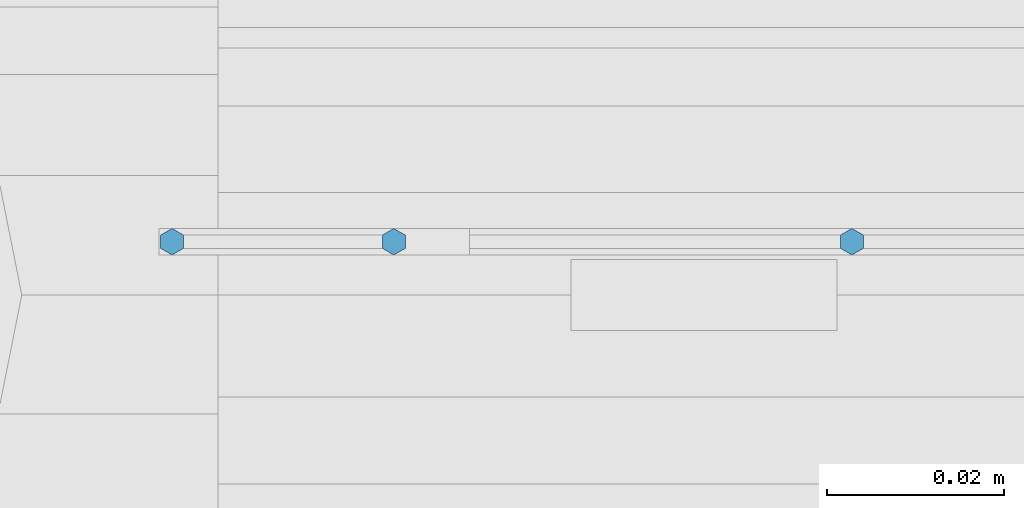
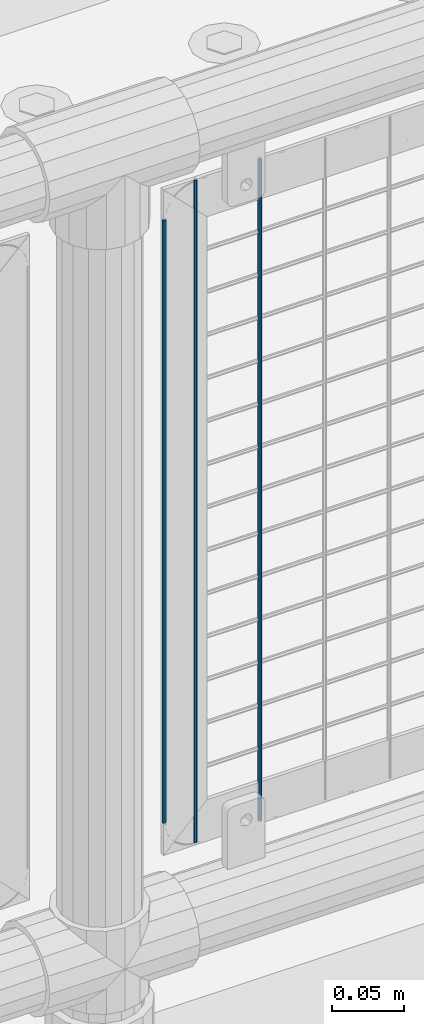
# One storey, part 62 of 193: 3 columns.
"""IFC2X3 building model written with IfcOpenShell, lengths in millimetres."""

from ifc_helpers import new_model, si_unit, frame, origin_with_axes, place, context, subcontext, project, spatial, faceted_brep, material, type_object, element, save


model = new_model("IFC2X3")

# Units and contexts
model_context = context("Model", 3, precision=1e-05, world=origin_with_axes())
body_context = subcontext(model_context, "Body", "Model", "MODEL_VIEW")
ifc_project = project(units=[si_unit("LENGTHUNIT", "METRE", prefix="MILLI"), si_unit("AREAUNIT", "SQUARE_METRE"), si_unit("VOLUMEUNIT", "CUBIC_METRE"), si_unit("MASSUNIT", "GRAM", prefix="KILO"), si_unit("TIMEUNIT", "SECOND"), si_unit("PLANEANGLEUNIT", "RADIAN"), si_unit("SOLIDANGLEUNIT", "STERADIAN"), si_unit("THERMODYNAMICTEMPERATUREUNIT", "DEGREE_CELSIUS"), si_unit("LUMINOUSINTENSITYUNIT", "LUMEN")], contexts=[model_context])

# Site, building, storey
site_placement = place(None, origin_with_axes())
site = spatial("IfcSite", under=ifc_project, at=site_placement, CompositionType="ELEMENT")
building_placement = place(site_placement, origin_with_axes())
building = spatial("IfcBuilding", under=site, at=building_placement, Name="Standard", CompositionType="ELEMENT")
storey_placement = place(building_placement, origin_with_axes())
storey = spatial("IfcBuildingStorey", under=building, at=storey_placement, Name="Undefined", CompositionType="ELEMENT", Elevation=0.0)

# Columns
ifc_material = material(Name="Misc_Undefined")
column_type = type_object("IfcColumnType", Name="D3", PredefinedType="NOTDEFINED")
column_1_placement = place(storey_placement, frame((-38381.345, 28670.5, 353.02), z_axis=(-1.0, 0.0, 0.0), x_axis=(0.0, 0.0, 1.0)))
element("IfcColumn", 1, at=column_1_placement, inside=storey, type_object=column_type, material=ifc_material, ObjectType="D3", context=body_context, shape_type="Brep", body=[
    faceted_brep([(0.0, -1.49999999999636, 3.63797880709171e-12), (0.0, -0.75, -1.29903810567669), (560.0, -0.75, -1.29903810567703), (560.0, -1.5, 0.0), (0.0, 0.75, -1.29903810567669), (560.0, 0.75, -1.29903810567703), (0.0, 1.50000000000364, 7.27595761418343e-12), (560.0, 1.5, 0.0), (0.0, 0.75, 1.29903810567669), (560.0, 0.75, 1.29903810567703), (0.0, -0.75, 1.29903810567669), (560.0, -0.75, 1.29903810567703)], [[[0, 1, 2, 3]], [[1, 4, 5, 2]], [[4, 6, 7, 5]], [[6, 8, 9, 7]], [[8, 10, 11, 9]], [[10, 0, 3, 11]], [[5, 7, 9, 11, 3, 2]], [[10, 8, 6, 4, 1, 0]]]),
])
column_2_placement = place(storey_placement, frame((-38458.0, 28670.5, 378.02), z_axis=(-1.0, 0.0, 0.0), x_axis=(0.0, 0.0, 1.0)))
element("IfcColumn", 2, at=column_2_placement, inside=storey, type_object=column_type, material=ifc_material, ObjectType="D3", context=body_context, shape_type="Brep", body=[
    faceted_brep([(0.0, -1.49999999999636, 3.63797880709171e-12), (0.0, -0.75, -1.29903810567669), (510.0, -0.75, -1.29903810567703), (510.0, -1.5, 0.0), (0.0, 0.75, -1.29903810567669), (510.0, 0.75, -1.29903810567703), (0.0, 1.50000000000364, 7.27595761418343e-12), (510.0, 1.5, 0.0), (0.0, 0.75, 1.29903810567669), (510.0, 0.75, 1.29903810567703), (0.0, -0.75, 1.29903810567669), (510.0, -0.75, 1.29903810567703)], [[[0, 1, 2, 3]], [[1, 4, 5, 2]], [[4, 6, 7, 5]], [[6, 8, 9, 7]], [[8, 10, 11, 9]], [[10, 0, 3, 11]], [[5, 7, 9, 11, 3, 2]], [[10, 8, 6, 4, 1, 0]]]),
])
column_3_placement = place(storey_placement, frame((-38433.0, 28670.5, 353.02), z_axis=(-1.0, 0.0, 0.0), x_axis=(0.0, 0.0, 1.0)))
element("IfcColumn", 3, at=column_3_placement, inside=storey, type_object=column_type, material=ifc_material, ObjectType="D3", context=body_context, shape_type="Brep", body=[
    faceted_brep([(0.0, -1.49999999999636, 3.63797880709171e-12), (0.0, -0.75, -1.29903810567669), (560.0, -0.75, -1.29903810567703), (560.0, -1.5, 0.0), (0.0, 0.75, -1.29903810567669), (560.0, 0.75, -1.29903810567703), (0.0, 1.50000000000364, 7.27595761418343e-12), (560.0, 1.5, 0.0), (0.0, 0.75, 1.29903810567669), (560.0, 0.75, 1.29903810567703), (0.0, -0.75, 1.29903810567669), (560.0, -0.75, 1.29903810567703)], [[[0, 1, 2, 3]], [[1, 4, 5, 2]], [[4, 6, 7, 5]], [[6, 8, 9, 7]], [[8, 10, 11, 9]], [[10, 0, 3, 11]], [[5, 7, 9, 11, 3, 2]], [[10, 8, 6, 4, 1, 0]]]),
])

save(model, "model.ifc")
